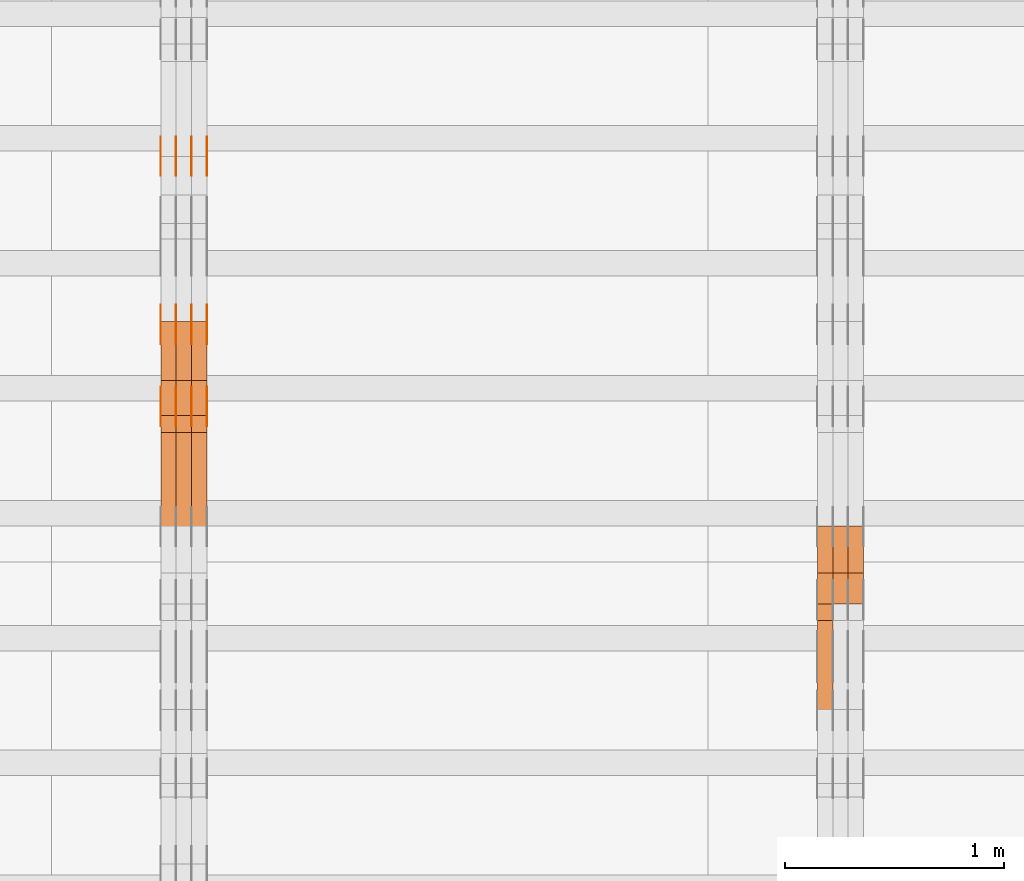
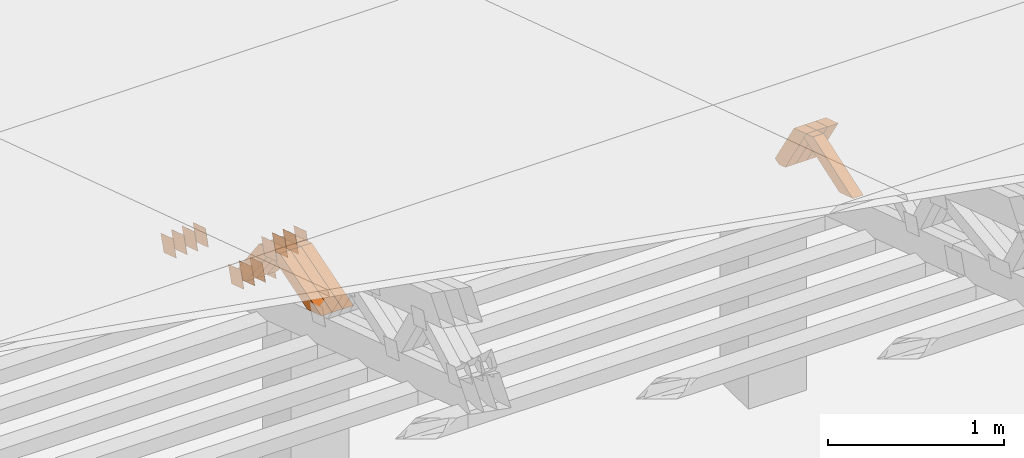
# One storey, part 227 of 385: 28 proxies.
"""IFC2X3 building model written with IfcOpenShell, lengths in millimetres."""

from ifc_helpers import new_model, entity, si_unit, converted_unit, derived_unit, direction, frame, origin, place, context, subcontext, project, spatial, polyline, outline, extrude, source, transform, mapped, material, type_object, type_shapes, element, save


model = new_model("IFC2X3")

# Units and contexts
model_context = context("Model", 3, precision=0.01, world=origin(), true_north=direction((6.12303176911189e-17, 1.0)))
body_context = subcontext(model_context, "Body", "Model", "MODEL_VIEW")
ifc_project = project(units=[si_unit("LENGTHUNIT", "METRE", prefix="MILLI"), si_unit("AREAUNIT", "SQUARE_METRE"), si_unit("VOLUMEUNIT", "CUBIC_METRE"), converted_unit("PLANEANGLEUNIT", "DEGREE", entity("IfcRatioMeasure", 0.0174532925199433), si_unit("PLANEANGLEUNIT", "RADIAN"), dimensions=[0, 0, 0, 0, 0, 0, 0]), si_unit("MASSUNIT", "GRAM", prefix="KILO"), derived_unit("MASSDENSITYUNIT", [(si_unit("MASSUNIT", "GRAM", prefix="KILO"), 1), (si_unit("LENGTHUNIT", "METRE"), -3)]), si_unit("TIMEUNIT", "SECOND"), si_unit("FREQUENCYUNIT", "HERTZ"), si_unit("THERMODYNAMICTEMPERATUREUNIT", "DEGREE_CELSIUS"), derived_unit("THERMALTRANSMITTANCEUNIT", [(si_unit("MASSUNIT", "GRAM", prefix="KILO"), 1), (si_unit("THERMODYNAMICTEMPERATUREUNIT", "KELVIN"), -1), (si_unit("TIMEUNIT", "SECOND"), -3)]), derived_unit("VOLUMETRICFLOWRATEUNIT", [(si_unit("LENGTHUNIT", "METRE"), 3), (si_unit("TIMEUNIT", "SECOND"), -1)]), si_unit("ELECTRICCURRENTUNIT", "AMPERE"), si_unit("ELECTRICVOLTAGEUNIT", "VOLT"), si_unit("POWERUNIT", "WATT"), si_unit("FORCEUNIT", "NEWTON", prefix="KILO"), si_unit("ILLUMINANCEUNIT", "LUX"), si_unit("LUMINOUSFLUXUNIT", "LUMEN"), si_unit("LUMINOUSINTENSITYUNIT", "CANDELA"), derived_unit("USERDEFINED", [(si_unit("MASSUNIT", "GRAM", prefix="KILO"), -1), (si_unit("LENGTHUNIT", "METRE"), -2), (si_unit("TIMEUNIT", "SECOND"), 3), (si_unit("LUMINOUSFLUXUNIT", "LUMEN"), 1)]), derived_unit("LINEARVELOCITYUNIT", [(si_unit("LENGTHUNIT", "METRE"), 1), (si_unit("TIMEUNIT", "SECOND"), -1)]), si_unit("PRESSUREUNIT", "PASCAL"), derived_unit("USERDEFINED", [(si_unit("LENGTHUNIT", "METRE"), -2), (si_unit("MASSUNIT", "GRAM", prefix="KILO"), 1), (si_unit("TIMEUNIT", "SECOND"), -2)])], contexts=[model_context])

# Site, building, storey
site_placement = place(None, origin())
site = spatial("IfcSite", under=ifc_project, at=site_placement, CompositionType="ELEMENT")
building_placement = place(site_placement, origin())
building = spatial("IfcBuilding", under=site, at=building_placement, CompositionType="ELEMENT")
storey_placement = place(building_placement, origin())
storey = spatial("IfcBuildingStorey", under=building, at=storey_placement, Name="Default", CompositionType="ELEMENT", Elevation=0.0)

# Proxies
ifc_material_1 = material(Name="IfcSurfaceStyle #324002")
building_element_proxy_type_1 = type_object("IfcBuildingElementProxyType", Name="T1-W26 324000", PredefinedType="NOTDEFINED", material=ifc_material_1)
shared_shape_1 = source(origin(), body_context, "Body", "SweptSolid", [
    extrude(outline(polyline([(-339.390941716546, -47.5001331548025), (137.738864791781, -47.5001331548025), (201.272298560955, 6.02772073885038e-05), (212.703852542003, 47.5001030161988), (-212.324074178193, 47.5001030161988), (-339.390941716546, -47.5001331548025)])), frame((212.703852542003, 47.5001030161988, 0.0), z_axis=(0.0, 0.0, 1.0), x_axis=(-1.0, 0.0, 0.0)), (0.0, 0.0, 1.0), 70.0),
])
type_shapes(building_element_proxy_type_1, [shared_shape_1])
proxy_1_placement = place(building_placement, frame((27245.0, 20576.541015625, 2286.80981445313), z_axis=(-1.0, 0.0, 0.0), x_axis=(0.0, -0.946743816465327, -0.321987804093053)))
element("IfcBuildingElementProxy", 1, at=proxy_1_placement, inside=storey, type_object=building_element_proxy_type_1, material=ifc_material_1, Name="T1-W26", context=body_context, shape_type="MappedRepresentation", body=[
    mapped(shared_shape_1, transform((0.0, 0.0, 0.0), scale=1.0)),
])
ifc_material_2 = material(Name="IfcSurfaceStyle #323738")
building_element_proxy_type_2 = type_object("IfcBuildingElementProxyType", Name="T1-W29 323736", PredefinedType="NOTDEFINED", material=ifc_material_2)
shared_shape_2 = source(origin(), body_context, "Body", "SweptSolid", [
    extrude(outline(polyline([(-202.325994317059, -47.5000867467013), (200.714255560873, -47.5000867467013), (187.834128885383, 0.000593513395139059), (130.590899902046, 47.4997899900038), (-316.813290031243, 47.4997899900038), (-202.325994317059, -47.5000867467013)])), frame((200.714255560873, 47.5001935424745, 0.0), z_axis=(0.0, 0.0, 1.0), x_axis=(-1.0, 0.0, 0.0)), (0.0, 0.0, 1.0), 70.0),
])
type_shapes(building_element_proxy_type_2, [shared_shape_2])
proxy_2_placement = place(building_placement, frame((27385.0, 20827.0771193222, 1890.72342063252), z_axis=(-1.0, 0.0, 0.0), x_axis=(0.0, -0.534567451138397, 0.845125813227473)))
element("IfcBuildingElementProxy", 2, at=proxy_2_placement, inside=storey, type_object=building_element_proxy_type_2, material=ifc_material_2, Name="T1-W29", context=body_context, shape_type="MappedRepresentation", body=[
    mapped(shared_shape_2, transform((0.0, 0.0, 0.0), scale=1.0)),
])
ifc_material_3 = material(Name="IfcSurfaceStyle #323672")
building_element_proxy_type_3 = type_object("IfcBuildingElementProxyType", Name="T1-W29 323670", PredefinedType="NOTDEFINED", material=ifc_material_3)
shared_shape_3 = source(origin(), body_context, "Body", "SweptSolid", [
    extrude(outline(polyline([(-202.325994317059, -47.5000867467013), (200.714255560873, -47.5000867467013), (187.834128885383, 0.000593513395139059), (130.590899902046, 47.4997899900038), (-316.813290031243, 47.4997899900038), (-202.325994317059, -47.5000867467013)])), frame((200.714255560873, 47.5001935424745, 0.0), z_axis=(0.0, 0.0, 1.0), x_axis=(-1.0, 0.0, 0.0)), (0.0, 0.0, 1.0), 70.0),
])
type_shapes(building_element_proxy_type_3, [shared_shape_3])
proxy_3_placement = place(building_placement, frame((27315.0, 20827.0771193222, 1890.72342063252), z_axis=(-1.0, 0.0, 0.0), x_axis=(0.0, -0.534567451138397, 0.845125813227473)))
element("IfcBuildingElementProxy", 3, at=proxy_3_placement, inside=storey, type_object=building_element_proxy_type_3, material=ifc_material_3, Name="T1-W29", context=body_context, shape_type="MappedRepresentation", body=[
    mapped(shared_shape_3, transform((0.0, 0.0, 0.0), scale=1.0)),
])
ifc_material_4 = material(Name="IfcSurfaceStyle #323606")
building_element_proxy_type_4 = type_object("IfcBuildingElementProxyType", Name="T1-W29 323604", PredefinedType="NOTDEFINED", material=ifc_material_4)
shared_shape_4 = source(origin(), body_context, "Body", "SweptSolid", [
    extrude(outline(polyline([(-202.325994317059, -47.5000867467013), (200.714255560873, -47.5000867467013), (187.834128885383, 0.000593513395139059), (130.590899902046, 47.4997899900038), (-316.813290031243, 47.4997899900038), (-202.325994317059, -47.5000867467013)])), frame((200.714255560873, 47.5001935424745, 0.0), z_axis=(0.0, 0.0, 1.0), x_axis=(-1.0, 0.0, 0.0)), (0.0, 0.0, 1.0), 70.0),
])
type_shapes(building_element_proxy_type_4, [shared_shape_4])
proxy_4_placement = place(building_placement, frame((27245.0, 20827.0771193222, 1890.72342063252), z_axis=(-1.0, 0.0, 0.0), x_axis=(0.0, -0.534567451138397, 0.845125813227473)))
element("IfcBuildingElementProxy", 4, at=proxy_4_placement, inside=storey, type_object=building_element_proxy_type_4, material=ifc_material_4, Name="T1-W29", context=body_context, shape_type="MappedRepresentation", body=[
    mapped(shared_shape_4, transform((0.0, 0.0, 0.0), scale=1.0)),
])
ifc_material_5 = material(Name="IfcSurfaceStyle #309700")
building_element_proxy_type_5 = type_object("IfcBuildingElementProxyType", PredefinedType="NOTDEFINED", material=ifc_material_5)
shared_shape_5 = source(origin(), body_context, "Body", "SweptSolid", [
    extrude(outline(polyline([(-74.9998794200123, -59.999984515643), (74.9998565677174, -59.999984515643), (74.9998794200123, 59.999984515643), (-74.9998565677174, 59.999984515643), (-74.9998794200123, -59.999984515643)])), frame((75.0000769557496, 60.0000596852268, 0.0), z_axis=(0.0, 0.0, 1.0), x_axis=(-1.0, 0.0, 0.0)), (0.0, 0.0, 1.0), 1.3),
])
type_shapes(building_element_proxy_type_5, [shared_shape_5])
proxy_5_placement = place(building_placement, frame((24386.3, 22649.3668870864, 1282.62115477841), z_axis=(-1.0, 0.0, 0.0), x_axis=(0.0, -0.951056516295124, 0.309016994375039)))
element("IfcBuildingElementProxy", 5, at=proxy_5_placement, inside=storey, type_object=building_element_proxy_type_5, material=ifc_material_5, context=body_context, shape_type="MappedRepresentation", body=[
    mapped(shared_shape_5, transform((0.0, 0.0, 0.0), scale=1.0)),
])
ifc_material_6 = material(Name="IfcSurfaceStyle #309643")
building_element_proxy_type_6 = type_object("IfcBuildingElementProxyType", PredefinedType="NOTDEFINED", material=ifc_material_6)
shared_shape_6 = source(origin(), body_context, "Body", "SweptSolid", [
    extrude(outline(polyline([(-74.9998794200123, -59.999984515643), (74.9998565677174, -59.999984515643), (74.9998794200123, 59.999984515643), (-74.9998565677174, 59.999984515643), (-74.9998794200123, -59.999984515643)])), frame((75.0000769557496, 60.0000596852268, 0.0), z_axis=(0.0, 0.0, 1.0), x_axis=(-1.0, 0.0, 0.0)), (0.0, 0.0, 1.0), 1.3),
])
type_shapes(building_element_proxy_type_6, [shared_shape_6])
proxy_6_placement = place(building_placement, frame((24315.0, 22649.3668870864, 1282.62115477841), z_axis=(-1.0, 0.0, 0.0), x_axis=(0.0, -0.951056516295124, 0.309016994375039)))
element("IfcBuildingElementProxy", 6, at=proxy_6_placement, inside=storey, type_object=building_element_proxy_type_6, material=ifc_material_6, context=body_context, shape_type="MappedRepresentation", body=[
    mapped(shared_shape_6, transform((0.0, 0.0, 0.0), scale=1.0)),
])
ifc_material_7 = material(Name="IfcSurfaceStyle #309586")
building_element_proxy_type_7 = type_object("IfcBuildingElementProxyType", PredefinedType="NOTDEFINED", material=ifc_material_7)
shared_shape_7 = source(origin(), body_context, "Body", "SweptSolid", [
    extrude(outline(polyline([(-74.9998794200123, -59.999984515643), (74.9998565677174, -59.999984515643), (74.9998794200123, 59.999984515643), (-74.9998565677174, 59.999984515643), (-74.9998794200123, -59.999984515643)])), frame((75.0000769557496, 60.0000596852268, 0.0), z_axis=(0.0, 0.0, 1.0), x_axis=(-1.0, 0.0, 0.0)), (0.0, 0.0, 1.0), 1.3),
])
type_shapes(building_element_proxy_type_7, [shared_shape_7])
proxy_7_placement = place(building_placement, frame((24316.3, 22649.3668870864, 1282.62115477841), z_axis=(-1.0, 0.0, 0.0), x_axis=(0.0, -0.951056516295124, 0.309016994375039)))
element("IfcBuildingElementProxy", 7, at=proxy_7_placement, inside=storey, type_object=building_element_proxy_type_7, material=ifc_material_7, context=body_context, shape_type="MappedRepresentation", body=[
    mapped(shared_shape_7, transform((0.0, 0.0, 0.0), scale=1.0)),
])
ifc_material_8 = material(Name="IfcSurfaceStyle #309529")
building_element_proxy_type_8 = type_object("IfcBuildingElementProxyType", PredefinedType="NOTDEFINED", material=ifc_material_8)
shared_shape_8 = source(origin(), body_context, "Body", "SweptSolid", [
    extrude(outline(polyline([(-74.9998794200123, -59.999984515643), (74.9998565677174, -59.999984515643), (74.9998794200123, 59.999984515643), (-74.9998565677174, 59.999984515643), (-74.9998794200123, -59.999984515643)])), frame((75.0000769557496, 60.0000596852268, 0.0), z_axis=(0.0, 0.0, 1.0), x_axis=(-1.0, 0.0, 0.0)), (0.0, 0.0, 1.0), 1.29999999999999),
])
type_shapes(building_element_proxy_type_8, [shared_shape_8])
proxy_8_placement = place(building_placement, frame((24245.0, 22649.3668870864, 1282.62115477841), z_axis=(-1.0, 0.0, 0.0), x_axis=(0.0, -0.951056516295124, 0.309016994375039)))
element("IfcBuildingElementProxy", 8, at=proxy_8_placement, inside=storey, type_object=building_element_proxy_type_8, material=ifc_material_8, context=body_context, shape_type="MappedRepresentation", body=[
    mapped(shared_shape_8, transform((0.0, 0.0, 0.0), scale=1.0)),
])
ifc_material_9 = material(Name="IfcSurfaceStyle #309472")
building_element_proxy_type_9 = type_object("IfcBuildingElementProxyType", PredefinedType="NOTDEFINED", material=ifc_material_9)
shared_shape_9 = source(origin(), body_context, "Body", "SweptSolid", [
    extrude(outline(polyline([(-74.9998794200123, -59.999984515643), (74.9998565677174, -59.999984515643), (74.9998794200123, 59.999984515643), (-74.9998565677174, 59.999984515643), (-74.9998794200123, -59.999984515643)])), frame((75.0000769557496, 60.0000596852268, 0.0), z_axis=(0.0, 0.0, 1.0), x_axis=(-1.0, 0.0, 0.0)), (0.0, 0.0, 1.0), 1.29999999999999),
])
type_shapes(building_element_proxy_type_9, [shared_shape_9])
proxy_9_placement = place(building_placement, frame((24246.3, 22649.3668870864, 1282.62115477841), z_axis=(-1.0, 0.0, 0.0), x_axis=(0.0, -0.951056516295124, 0.309016994375039)))
element("IfcBuildingElementProxy", 9, at=proxy_9_placement, inside=storey, type_object=building_element_proxy_type_9, material=ifc_material_9, context=body_context, shape_type="MappedRepresentation", body=[
    mapped(shared_shape_9, transform((0.0, 0.0, 0.0), scale=1.0)),
])
ifc_material_10 = material(Name="IfcSurfaceStyle #309415")
building_element_proxy_type_10 = type_object("IfcBuildingElementProxyType", PredefinedType="NOTDEFINED", material=ifc_material_10)
shared_shape_10 = source(origin(), body_context, "Body", "SweptSolid", [
    extrude(outline(polyline([(-74.9998794200123, -59.999984515643), (74.9998565677174, -59.999984515643), (74.9998794200123, 59.999984515643), (-74.9998565677174, 59.999984515643), (-74.9998794200123, -59.999984515643)])), frame((75.0000769557496, 60.0000596852268, 0.0), z_axis=(0.0, 0.0, 1.0), x_axis=(-1.0, 0.0, 0.0)), (0.0, 0.0, 1.0), 1.29999999999999),
])
type_shapes(building_element_proxy_type_10, [shared_shape_10])
proxy_10_placement = place(building_placement, frame((24175.0, 22649.3668870864, 1282.62115477841), z_axis=(-1.0, 0.0, 0.0), x_axis=(0.0, -0.951056516295124, 0.309016994375039)))
element("IfcBuildingElementProxy", 10, at=proxy_10_placement, inside=storey, type_object=building_element_proxy_type_10, material=ifc_material_10, context=body_context, shape_type="MappedRepresentation", body=[
    mapped(shared_shape_10, transform((0.0, 0.0, 0.0), scale=1.0)),
])
ifc_material_11 = material(Name="IfcSurfaceStyle #306622")
building_element_proxy_type_11 = type_object("IfcBuildingElementProxyType", PredefinedType="NOTDEFINED", material=ifc_material_11)
shared_shape_11 = source(origin(), body_context, "Body", "SweptSolid", [
    extrude(outline(polyline([(-75.0001116115454, -60.0000599592451), (75.0000887592496, -60.0000599592451), (75.0001116115454, 60.0000599592451), (-75.0000887592496, 60.0000599592451), (-75.0001116115454, -60.0000599592451)])), frame((75.0001116115454, 60.0000599592451, 0.0), z_axis=(0.0, 0.0, 1.0), x_axis=(-1.0, 0.0, 0.0)), (0.0, 0.0, 1.0), 1.3),
])
type_shapes(building_element_proxy_type_11, [shared_shape_11])
proxy_11_placement = place(building_placement, frame((24386.3, 21881.0815195707, 1532.2522473242), z_axis=(-1.0, 0.0, 0.0), x_axis=(0.0, -0.951056516295124, 0.309016994375039)))
element("IfcBuildingElementProxy", 11, at=proxy_11_placement, inside=storey, type_object=building_element_proxy_type_11, material=ifc_material_11, context=body_context, shape_type="MappedRepresentation", body=[
    mapped(shared_shape_11, transform((0.0, 0.0, 0.0), scale=1.0)),
])
ifc_material_12 = material(Name="IfcSurfaceStyle #306565")
building_element_proxy_type_12 = type_object("IfcBuildingElementProxyType", PredefinedType="NOTDEFINED", material=ifc_material_12)
shared_shape_12 = source(origin(), body_context, "Body", "SweptSolid", [
    extrude(outline(polyline([(-75.0001116115454, -60.0000599592451), (75.0000887592496, -60.0000599592451), (75.0001116115454, 60.0000599592451), (-75.0000887592496, 60.0000599592451), (-75.0001116115454, -60.0000599592451)])), frame((75.0001116115454, 60.0000599592451, 0.0), z_axis=(0.0, 0.0, 1.0), x_axis=(-1.0, 0.0, 0.0)), (0.0, 0.0, 1.0), 1.3),
])
type_shapes(building_element_proxy_type_12, [shared_shape_12])
proxy_12_placement = place(building_placement, frame((24315.0, 21881.0815195707, 1532.2522473242), z_axis=(-1.0, 0.0, 0.0), x_axis=(0.0, -0.951056516295124, 0.309016994375039)))
element("IfcBuildingElementProxy", 12, at=proxy_12_placement, inside=storey, type_object=building_element_proxy_type_12, material=ifc_material_12, context=body_context, shape_type="MappedRepresentation", body=[
    mapped(shared_shape_12, transform((0.0, 0.0, 0.0), scale=1.0)),
])
ifc_material_13 = material(Name="IfcSurfaceStyle #306508")
building_element_proxy_type_13 = type_object("IfcBuildingElementProxyType", PredefinedType="NOTDEFINED", material=ifc_material_13)
shared_shape_13 = source(origin(), body_context, "Body", "SweptSolid", [
    extrude(outline(polyline([(-75.0001116115454, -60.0000599592451), (75.0000887592496, -60.0000599592451), (75.0001116115454, 60.0000599592451), (-75.0000887592496, 60.0000599592451), (-75.0001116115454, -60.0000599592451)])), frame((75.0001116115454, 60.0000599592451, 0.0), z_axis=(0.0, 0.0, 1.0), x_axis=(-1.0, 0.0, 0.0)), (0.0, 0.0, 1.0), 1.3),
])
type_shapes(building_element_proxy_type_13, [shared_shape_13])
proxy_13_placement = place(building_placement, frame((24316.3, 21881.0815195707, 1532.2522473242), z_axis=(-1.0, 0.0, 0.0), x_axis=(0.0, -0.951056516295124, 0.309016994375039)))
element("IfcBuildingElementProxy", 13, at=proxy_13_placement, inside=storey, type_object=building_element_proxy_type_13, material=ifc_material_13, context=body_context, shape_type="MappedRepresentation", body=[
    mapped(shared_shape_13, transform((0.0, 0.0, 0.0), scale=1.0)),
])
ifc_material_14 = material(Name="IfcSurfaceStyle #306451")
building_element_proxy_type_14 = type_object("IfcBuildingElementProxyType", PredefinedType="NOTDEFINED", material=ifc_material_14)
shared_shape_14 = source(origin(), body_context, "Body", "SweptSolid", [
    extrude(outline(polyline([(-75.0001116115454, -60.0000599592451), (75.0000887592496, -60.0000599592451), (75.0001116115454, 60.0000599592451), (-75.0000887592496, 60.0000599592451), (-75.0001116115454, -60.0000599592451)])), frame((75.0001116115454, 60.0000599592451, 0.0), z_axis=(0.0, 0.0, 1.0), x_axis=(-1.0, 0.0, 0.0)), (0.0, 0.0, 1.0), 1.29999999999999),
])
type_shapes(building_element_proxy_type_14, [shared_shape_14])
proxy_14_placement = place(building_placement, frame((24245.0, 21881.0815195707, 1532.2522473242), z_axis=(-1.0, 0.0, 0.0), x_axis=(0.0, -0.951056516295124, 0.309016994375039)))
element("IfcBuildingElementProxy", 14, at=proxy_14_placement, inside=storey, type_object=building_element_proxy_type_14, material=ifc_material_14, context=body_context, shape_type="MappedRepresentation", body=[
    mapped(shared_shape_14, transform((0.0, 0.0, 0.0), scale=1.0)),
])
ifc_material_15 = material(Name="IfcSurfaceStyle #306394")
building_element_proxy_type_15 = type_object("IfcBuildingElementProxyType", PredefinedType="NOTDEFINED", material=ifc_material_15)
shared_shape_15 = source(origin(), body_context, "Body", "SweptSolid", [
    extrude(outline(polyline([(-75.0001116115454, -60.0000599592451), (75.0000887592496, -60.0000599592451), (75.0001116115454, 60.0000599592451), (-75.0000887592496, 60.0000599592451), (-75.0001116115454, -60.0000599592451)])), frame((75.0001116115454, 60.0000599592451, 0.0), z_axis=(0.0, 0.0, 1.0), x_axis=(-1.0, 0.0, 0.0)), (0.0, 0.0, 1.0), 1.29999999999999),
])
type_shapes(building_element_proxy_type_15, [shared_shape_15])
proxy_15_placement = place(building_placement, frame((24246.3, 21881.0815195707, 1532.2522473242), z_axis=(-1.0, 0.0, 0.0), x_axis=(0.0, -0.951056516295124, 0.309016994375039)))
element("IfcBuildingElementProxy", 15, at=proxy_15_placement, inside=storey, type_object=building_element_proxy_type_15, material=ifc_material_15, context=body_context, shape_type="MappedRepresentation", body=[
    mapped(shared_shape_15, transform((0.0, 0.0, 0.0), scale=1.0)),
])
ifc_material_16 = material(Name="IfcSurfaceStyle #306337")
building_element_proxy_type_16 = type_object("IfcBuildingElementProxyType", PredefinedType="NOTDEFINED", material=ifc_material_16)
shared_shape_16 = source(origin(), body_context, "Body", "SweptSolid", [
    extrude(outline(polyline([(-75.0001116115454, -60.0000599592451), (75.0000887592496, -60.0000599592451), (75.0001116115454, 60.0000599592451), (-75.0000887592496, 60.0000599592451), (-75.0001116115454, -60.0000599592451)])), frame((75.0001116115454, 60.0000599592451, 0.0), z_axis=(0.0, 0.0, 1.0), x_axis=(-1.0, 0.0, 0.0)), (0.0, 0.0, 1.0), 1.29999999999999),
])
type_shapes(building_element_proxy_type_16, [shared_shape_16])
proxy_16_placement = place(building_placement, frame((24175.0, 21881.0815195707, 1532.2522473242), z_axis=(-1.0, 0.0, 0.0), x_axis=(0.0, -0.951056516295124, 0.309016994375039)))
element("IfcBuildingElementProxy", 16, at=proxy_16_placement, inside=storey, type_object=building_element_proxy_type_16, material=ifc_material_16, context=body_context, shape_type="MappedRepresentation", body=[
    mapped(shared_shape_16, transform((0.0, 0.0, 0.0), scale=1.0)),
])
ifc_material_17 = material(Name="IfcSurfaceStyle #301150")
building_element_proxy_type_17 = type_object("IfcBuildingElementProxyType", PredefinedType="NOTDEFINED", material=ifc_material_17)
shared_shape_17 = source(origin(), body_context, "Body", "SweptSolid", [
    extrude(outline(polyline([(-74.9998794200064, -59.9999845156358), (74.9998565677224, -59.9999845156358), (74.9998794200064, 59.9999845156358), (-74.9998565677224, 59.9999845156358), (-74.9998794200064, -59.9999845156358)])), frame((74.9999765995044, 60.0000596852337, 0.0), z_axis=(0.0, 0.0, 1.0), x_axis=(-1.0, 0.0, 0.0)), (0.0, 0.0, 1.0), 1.3),
])
type_shapes(building_element_proxy_type_17, [shared_shape_17])
proxy_17_placement = place(building_placement, frame((24386.3, 21505.9776314857, 1954.5332951652), z_axis=(-1.0, 0.0, 0.0), x_axis=(0.0, -0.951056516295154, 0.309016994374948)))
element("IfcBuildingElementProxy", 17, at=proxy_17_placement, inside=storey, type_object=building_element_proxy_type_17, material=ifc_material_17, context=body_context, shape_type="MappedRepresentation", body=[
    mapped(shared_shape_17, transform((0.0, 0.0, 0.0), scale=1.0)),
])
ifc_material_18 = material(Name="IfcSurfaceStyle #301093")
building_element_proxy_type_18 = type_object("IfcBuildingElementProxyType", PredefinedType="NOTDEFINED", material=ifc_material_18)
shared_shape_18 = source(origin(), body_context, "Body", "SweptSolid", [
    extrude(outline(polyline([(-74.9998794200064, -59.9999845156358), (74.9998565677224, -59.9999845156358), (74.9998794200064, 59.9999845156358), (-74.9998565677224, 59.9999845156358), (-74.9998794200064, -59.9999845156358)])), frame((74.9999765995044, 60.0000596852337, 0.0), z_axis=(0.0, 0.0, 1.0), x_axis=(-1.0, 0.0, 0.0)), (0.0, 0.0, 1.0), 1.3),
])
type_shapes(building_element_proxy_type_18, [shared_shape_18])
proxy_18_placement = place(building_placement, frame((24315.0, 21505.9776314857, 1954.5332951652), z_axis=(-1.0, 0.0, 0.0), x_axis=(0.0, -0.951056516295154, 0.309016994374948)))
element("IfcBuildingElementProxy", 18, at=proxy_18_placement, inside=storey, type_object=building_element_proxy_type_18, material=ifc_material_18, context=body_context, shape_type="MappedRepresentation", body=[
    mapped(shared_shape_18, transform((0.0, 0.0, 0.0), scale=1.0)),
])
ifc_material_19 = material(Name="IfcSurfaceStyle #301036")
building_element_proxy_type_19 = type_object("IfcBuildingElementProxyType", PredefinedType="NOTDEFINED", material=ifc_material_19)
shared_shape_19 = source(origin(), body_context, "Body", "SweptSolid", [
    extrude(outline(polyline([(-74.9998794200064, -59.9999845156358), (74.9998565677224, -59.9999845156358), (74.9998794200064, 59.9999845156358), (-74.9998565677224, 59.9999845156358), (-74.9998794200064, -59.9999845156358)])), frame((74.9999765995044, 60.0000596852337, 0.0), z_axis=(0.0, 0.0, 1.0), x_axis=(-1.0, 0.0, 0.0)), (0.0, 0.0, 1.0), 1.3),
])
type_shapes(building_element_proxy_type_19, [shared_shape_19])
proxy_19_placement = place(building_placement, frame((24316.3, 21505.9776314857, 1954.5332951652), z_axis=(-1.0, 0.0, 0.0), x_axis=(0.0, -0.951056516295154, 0.309016994374948)))
element("IfcBuildingElementProxy", 19, at=proxy_19_placement, inside=storey, type_object=building_element_proxy_type_19, material=ifc_material_19, context=body_context, shape_type="MappedRepresentation", body=[
    mapped(shared_shape_19, transform((0.0, 0.0, 0.0), scale=1.0)),
])
ifc_material_20 = material(Name="IfcSurfaceStyle #300979")
building_element_proxy_type_20 = type_object("IfcBuildingElementProxyType", PredefinedType="NOTDEFINED", material=ifc_material_20)
shared_shape_20 = source(origin(), body_context, "Body", "SweptSolid", [
    extrude(outline(polyline([(-74.9998794200064, -59.9999845156358), (74.9998565677224, -59.9999845156358), (74.9998794200064, 59.9999845156358), (-74.9998565677224, 59.9999845156358), (-74.9998794200064, -59.9999845156358)])), frame((74.9999765995044, 60.0000596852337, 0.0), z_axis=(0.0, 0.0, 1.0), x_axis=(-1.0, 0.0, 0.0)), (0.0, 0.0, 1.0), 1.29999999999999),
])
type_shapes(building_element_proxy_type_20, [shared_shape_20])
proxy_20_placement = place(building_placement, frame((24245.0, 21505.9776314857, 1954.5332951652), z_axis=(-1.0, 0.0, 0.0), x_axis=(0.0, -0.951056516295154, 0.309016994374948)))
element("IfcBuildingElementProxy", 20, at=proxy_20_placement, inside=storey, type_object=building_element_proxy_type_20, material=ifc_material_20, context=body_context, shape_type="MappedRepresentation", body=[
    mapped(shared_shape_20, transform((0.0, 0.0, 0.0), scale=1.0)),
])
ifc_material_21 = material(Name="IfcSurfaceStyle #300922")
building_element_proxy_type_21 = type_object("IfcBuildingElementProxyType", PredefinedType="NOTDEFINED", material=ifc_material_21)
shared_shape_21 = source(origin(), body_context, "Body", "SweptSolid", [
    extrude(outline(polyline([(-74.9998794200064, -59.9999845156358), (74.9998565677224, -59.9999845156358), (74.9998794200064, 59.9999845156358), (-74.9998565677224, 59.9999845156358), (-74.9998794200064, -59.9999845156358)])), frame((74.9999765995044, 60.0000596852337, 0.0), z_axis=(0.0, 0.0, 1.0), x_axis=(-1.0, 0.0, 0.0)), (0.0, 0.0, 1.0), 1.29999999999999),
])
type_shapes(building_element_proxy_type_21, [shared_shape_21])
proxy_21_placement = place(building_placement, frame((24246.3, 21505.9776314857, 1954.5332951652), z_axis=(-1.0, 0.0, 0.0), x_axis=(0.0, -0.951056516295154, 0.309016994374948)))
element("IfcBuildingElementProxy", 21, at=proxy_21_placement, inside=storey, type_object=building_element_proxy_type_21, material=ifc_material_21, context=body_context, shape_type="MappedRepresentation", body=[
    mapped(shared_shape_21, transform((0.0, 0.0, 0.0), scale=1.0)),
])
ifc_material_22 = material(Name="IfcSurfaceStyle #300865")
building_element_proxy_type_22 = type_object("IfcBuildingElementProxyType", PredefinedType="NOTDEFINED", material=ifc_material_22)
shared_shape_22 = source(origin(), body_context, "Body", "SweptSolid", [
    extrude(outline(polyline([(-74.9998794200064, -59.9999845156358), (74.9998565677224, -59.9999845156358), (74.9998794200064, 59.9999845156358), (-74.9998565677224, 59.9999845156358), (-74.9998794200064, -59.9999845156358)])), frame((74.9999765995044, 60.0000596852337, 0.0), z_axis=(0.0, 0.0, 1.0), x_axis=(-1.0, 0.0, 0.0)), (0.0, 0.0, 1.0), 1.29999999999999),
])
type_shapes(building_element_proxy_type_22, [shared_shape_22])
proxy_22_placement = place(building_placement, frame((24175.0, 21505.9776314857, 1954.5332951652), z_axis=(-1.0, 0.0, 0.0), x_axis=(0.0, -0.951056516295154, 0.309016994374948)))
element("IfcBuildingElementProxy", 22, at=proxy_22_placement, inside=storey, type_object=building_element_proxy_type_22, material=ifc_material_22, context=body_context, shape_type="MappedRepresentation", body=[
    mapped(shared_shape_22, transform((0.0, 0.0, 0.0), scale=1.0)),
])
ifc_material_23 = material(Name="IfcSurfaceStyle #288910")
building_element_proxy_type_23 = type_object("IfcBuildingElementProxyType", Name="T1-W20 288908", PredefinedType="NOTDEFINED", material=ifc_material_23)
shared_shape_23 = source(origin(), body_context, "Body", "SweptSolid", [
    extrude(outline(polyline([(-355.264945969921, -47.5000317999193), (141.064821099313, -47.5000317999193), (208.541978467889, 8.19311626391928e-05), (225.96877763549, 47.499990834338), (-220.31063123277, 47.4999908343379), (-355.264945969921, -47.5000317999193)])), frame((225.968921063481, 47.5000683592689, 0.0), z_axis=(0.0, 0.0, 1.0), x_axis=(-1.0, 0.0, 0.0)), (0.0, 0.0, 1.0), 70.0),
])
type_shapes(building_element_proxy_type_23, [shared_shape_23])
proxy_23_placement = place(building_placement, frame((24385.0, 21443.7472302196, 2007.54830804072), z_axis=(-1.0, 0.0, 0.0), x_axis=(0.0, -0.95556995517236, -0.29476441571515)))
element("IfcBuildingElementProxy", 23, at=proxy_23_placement, inside=storey, type_object=building_element_proxy_type_23, material=ifc_material_23, Name="T1-W20", context=body_context, shape_type="MappedRepresentation", body=[
    mapped(shared_shape_23, transform((0.0, 0.0, 0.0), scale=1.0)),
])
ifc_material_24 = material(Name="IfcSurfaceStyle #288844")
building_element_proxy_type_24 = type_object("IfcBuildingElementProxyType", Name="T1-W20 288842", PredefinedType="NOTDEFINED", material=ifc_material_24)
shared_shape_24 = source(origin(), body_context, "Body", "SweptSolid", [
    extrude(outline(polyline([(-355.264945969921, -47.5000317999193), (141.064821099313, -47.5000317999193), (208.541978467889, 8.19311626391928e-05), (225.96877763549, 47.499990834338), (-220.31063123277, 47.4999908343379), (-355.264945969921, -47.5000317999193)])), frame((225.968921063481, 47.5000683592689, 0.0), z_axis=(0.0, 0.0, 1.0), x_axis=(-1.0, 0.0, 0.0)), (0.0, 0.0, 1.0), 70.0),
])
type_shapes(building_element_proxy_type_24, [shared_shape_24])
proxy_24_placement = place(building_placement, frame((24315.0, 21443.7472302196, 2007.54830804072), z_axis=(-1.0, 0.0, 0.0), x_axis=(0.0, -0.95556995517236, -0.29476441571515)))
element("IfcBuildingElementProxy", 24, at=proxy_24_placement, inside=storey, type_object=building_element_proxy_type_24, material=ifc_material_24, Name="T1-W20", context=body_context, shape_type="MappedRepresentation", body=[
    mapped(shared_shape_24, transform((0.0, 0.0, 0.0), scale=1.0)),
])
ifc_material_25 = material(Name="IfcSurfaceStyle #288778")
building_element_proxy_type_25 = type_object("IfcBuildingElementProxyType", Name="T1-W20 288776", PredefinedType="NOTDEFINED", material=ifc_material_25)
shared_shape_25 = source(origin(), body_context, "Body", "SweptSolid", [
    extrude(outline(polyline([(-355.264945969921, -47.5000317999193), (141.064821099313, -47.5000317999193), (208.541978467889, 8.19311626391928e-05), (225.96877763549, 47.499990834338), (-220.31063123277, 47.4999908343379), (-355.264945969921, -47.5000317999193)])), frame((225.968921063481, 47.5000683592689, 0.0), z_axis=(0.0, 0.0, 1.0), x_axis=(-1.0, 0.0, 0.0)), (0.0, 0.0, 1.0), 70.0),
])
type_shapes(building_element_proxy_type_25, [shared_shape_25])
proxy_25_placement = place(building_placement, frame((24245.0, 21443.7472302196, 2007.54830804072), z_axis=(-1.0, 0.0, 0.0), x_axis=(0.0, -0.95556995517236, -0.29476441571515)))
element("IfcBuildingElementProxy", 25, at=proxy_25_placement, inside=storey, type_object=building_element_proxy_type_25, material=ifc_material_25, Name="T1-W20", context=body_context, shape_type="MappedRepresentation", body=[
    mapped(shared_shape_25, transform((0.0, 0.0, 0.0), scale=1.0)),
])
ifc_material_26 = material(Name="IfcSurfaceStyle #288514")
building_element_proxy_type_26 = type_object("IfcBuildingElementProxyType", Name="T1-W18 288512", PredefinedType="NOTDEFINED", material=ifc_material_26)
shared_shape_26 = source(origin(), body_context, "Body", "SweptSolid", [
    extrude(outline(polyline([(-221.504996322134, -47.4999929258616), (225.406467948779, -47.4999929258616), (211.663832468686, -0.000107703153482008), (143.08905281687, 47.5000467774384), (-358.6543569122, 47.5000467774384), (-221.504996322134, -47.4999929258616)])), frame((225.406576158364, 47.5000467774384, 0.0), z_axis=(0.0, 0.0, 1.0), x_axis=(-1.0, 0.0, 0.0)), (0.0, 0.0, 1.0), 70.0),
])
type_shapes(building_element_proxy_type_26, [shared_shape_26])
proxy_26_placement = place(building_placement, frame((24385.0, 21766.9513837803, 1583.13813361817), z_axis=(-1.0, 0.0, 0.0), x_axis=(0.0, -0.605858491298265, 0.795572428206126)))
element("IfcBuildingElementProxy", 26, at=proxy_26_placement, inside=storey, type_object=building_element_proxy_type_26, material=ifc_material_26, Name="T1-W18", context=body_context, shape_type="MappedRepresentation", body=[
    mapped(shared_shape_26, transform((0.0, 0.0, 0.0), scale=1.0)),
])
ifc_material_27 = material(Name="IfcSurfaceStyle #288448")
building_element_proxy_type_27 = type_object("IfcBuildingElementProxyType", Name="T1-W18 288446", PredefinedType="NOTDEFINED", material=ifc_material_27)
shared_shape_27 = source(origin(), body_context, "Body", "SweptSolid", [
    extrude(outline(polyline([(-221.504996322134, -47.4999929258616), (225.406467948779, -47.4999929258616), (211.663832468686, -0.000107703153482008), (143.08905281687, 47.5000467774384), (-358.6543569122, 47.5000467774384), (-221.504996322134, -47.4999929258616)])), frame((225.406576158364, 47.5000467774384, 0.0), z_axis=(0.0, 0.0, 1.0), x_axis=(-1.0, 0.0, 0.0)), (0.0, 0.0, 1.0), 70.0),
])
type_shapes(building_element_proxy_type_27, [shared_shape_27])
proxy_27_placement = place(building_placement, frame((24315.0, 21766.9513837803, 1583.13813361817), z_axis=(-1.0, 0.0, 0.0), x_axis=(0.0, -0.605858491298265, 0.795572428206126)))
element("IfcBuildingElementProxy", 27, at=proxy_27_placement, inside=storey, type_object=building_element_proxy_type_27, material=ifc_material_27, Name="T1-W18", context=body_context, shape_type="MappedRepresentation", body=[
    mapped(shared_shape_27, transform((0.0, 0.0, 0.0), scale=1.0)),
])
ifc_material_28 = material(Name="IfcSurfaceStyle #288382")
building_element_proxy_type_28 = type_object("IfcBuildingElementProxyType", Name="T1-W18 288380", PredefinedType="NOTDEFINED", material=ifc_material_28)
shared_shape_28 = source(origin(), body_context, "Body", "SweptSolid", [
    extrude(outline(polyline([(-221.504996322134, -47.4999929258616), (225.406467948779, -47.4999929258616), (211.663832468686, -0.000107703153482008), (143.08905281687, 47.5000467774384), (-358.6543569122, 47.5000467774384), (-221.504996322134, -47.4999929258616)])), frame((225.406576158364, 47.5000467774384, 0.0), z_axis=(0.0, 0.0, 1.0), x_axis=(-1.0, 0.0, 0.0)), (0.0, 0.0, 1.0), 70.0),
])
type_shapes(building_element_proxy_type_28, [shared_shape_28])
proxy_28_placement = place(building_placement, frame((24245.0, 21766.9513837803, 1583.13813361817), z_axis=(-1.0, 0.0, 0.0), x_axis=(0.0, -0.605858491298265, 0.795572428206126)))
element("IfcBuildingElementProxy", 28, at=proxy_28_placement, inside=storey, type_object=building_element_proxy_type_28, material=ifc_material_28, Name="T1-W18", context=body_context, shape_type="MappedRepresentation", body=[
    mapped(shared_shape_28, transform((0.0, 0.0, 0.0), scale=1.0)),
])

save(model, "model.ifc")
